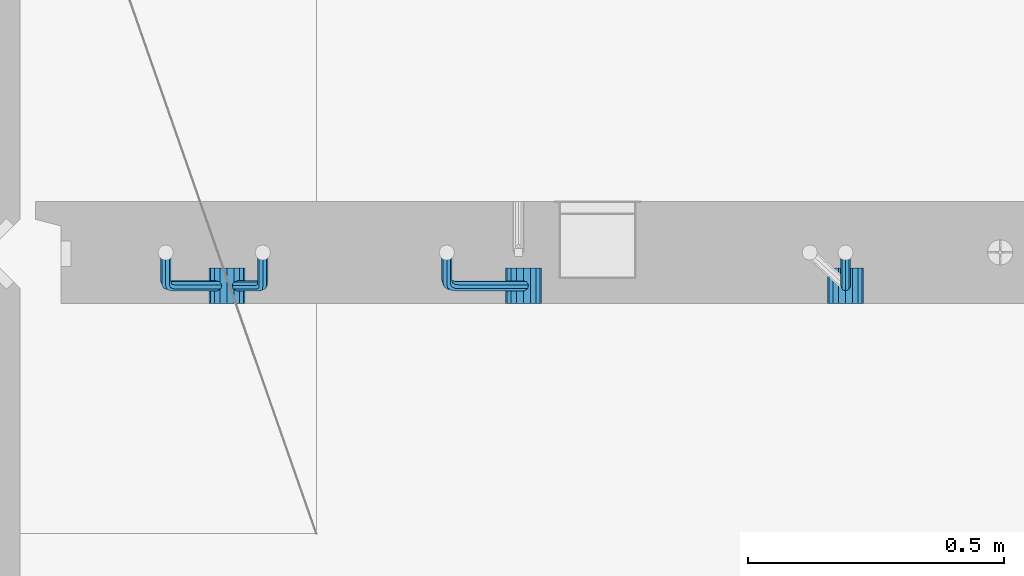
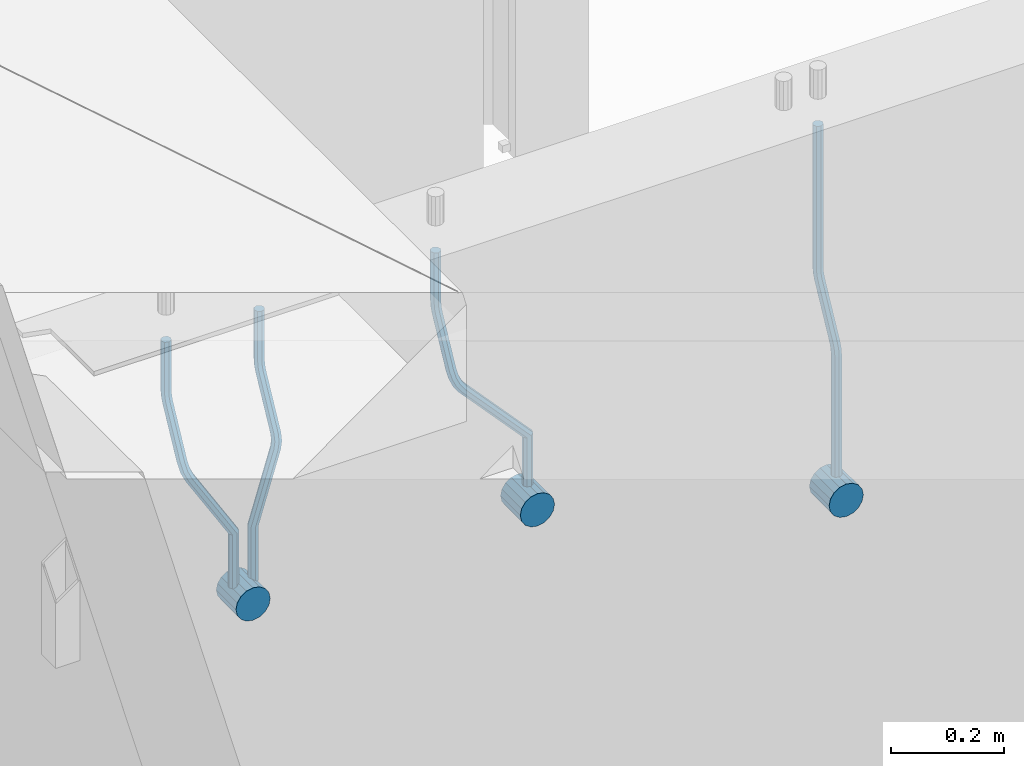
# One storey, part 154 of 352: 7 beams, 1 element without a shape of its own.
"""IFC2X3 building model written with IfcOpenShell, lengths in millimetres."""

from ifc_helpers import new_model, si_unit, frame, origin_with_axes, place, context, subcontext, project, spatial, faceted_brep, material, type_object, element, aggregate, save


model = new_model("IFC2X3")

# Units and contexts
model_context = context("Model", 3, precision=1e-05, world=origin_with_axes())
body_context = subcontext(model_context, "Body", "Model", "MODEL_VIEW")
ifc_project = project(units=[si_unit("LENGTHUNIT", "METRE", prefix="MILLI"), si_unit("AREAUNIT", "SQUARE_METRE"), si_unit("VOLUMEUNIT", "CUBIC_METRE"), si_unit("MASSUNIT", "GRAM", prefix="KILO"), si_unit("TIMEUNIT", "SECOND"), si_unit("PLANEANGLEUNIT", "RADIAN"), si_unit("SOLIDANGLEUNIT", "STERADIAN"), si_unit("THERMODYNAMICTEMPERATUREUNIT", "DEGREE_CELSIUS"), si_unit("LUMINOUSINTENSITYUNIT", "LUMEN")], contexts=[model_context])

# Site, building, storey
site_placement = place(None, origin_with_axes())
site = spatial("IfcSite", under=ifc_project, at=site_placement, CompositionType="ELEMENT")
building_placement = place(site_placement, origin_with_axes())
building = spatial("IfcBuilding", under=site, at=building_placement, CompositionType="ELEMENT")
storey_placement = place(building_placement, origin_with_axes())
storey = spatial("IfcBuildingStorey", under=building, at=storey_placement, Name="6", CompositionType="ELEMENT", Elevation=0.0)

# Assembly, beams
assembly_placement = place(storey_placement, origin_with_axes())
assembly = element("IfcElementAssembly", 1, at=assembly_placement, inside=storey, AssemblyPlace="NOTDEFINED", PredefinedType="REINFORCEMENT_UNIT")
ifc_material = material()
beam_type_1 = type_object("IfcBeamType", Name="D20", PredefinedType="NOTDEFINED")
beam_1_placement = place(assembly_placement, frame((9615.0034031366, 16979.9000008034, 99407.5), z_axis=(-0.000415599999849952, -0.999999913638316, 0.0), x_axis=(0.0, 0.0, -1.0)))
beam_1 = element("IfcBeam", 2, at=beam_1_placement, type_object=beam_type_1, material=ifc_material, Name="JM20", ObjectType="D20", context=body_context, shape_type="Brep", body=[
    faceted_brep([(0.0, -10.0, 0.0), (-4.19531716033816e-08, -7.07106781186667, -7.07106781187031), (308.817759199839, -7.07106784567077, -7.07106781098628), (308.817759199388, -10.0000000315576, 1.18961906991899e-09), (0.0, 0.0, -10.0), (308.817759200625, -3.38059180648997e-08, -9.99999999911961), (4.196772351861e-08, 7.07106781186303, -7.07106781186667), (308.817759201396, 7.07106777806075, -7.07106781098992), (0.0, 10.0, 0.0), (308.817759201687, 9.99999996619408, 8.76752892509103e-10), (4.196772351861e-08, 7.07106781185939, 7.07106781185939), (308.817759201353, 7.07106777805893, 7.07106781273978), (0.0, 0.0, 10.0), (308.817759200567, -3.38059180648997e-08, 10.0000000008768), (-4.19531716033816e-08, -7.07106781187031, 7.07106781185939), (308.817759199781, -7.07106784567259, 7.07106781274342), (323.108969574154, 0.000717635259206872, -8.27316123493802), (322.412036484602, -7.07038517474393, -5.42844102338131), (320.72809124495, -9.99940192615759, 1.43915193649809), (319.043566138222, -7.07055433041933, 8.30667482965873), (318.345233125816, 0.000478413006931078, 11.1512258851908), (319.042166215368, 7.07158122300643, 8.30650567364501), (320.726111455049, 10.0005979744237, 1.4389127137656), (322.410636561748, 7.07175037869092, -5.42861017940231), (335.221090258594, 7.07375888522984, -0.59577927861028), (336.577559329642, 0.00282932867594354, -3.19204402394098), (331.949003496353, 10.0023575726736, 5.67282516818887), (328.678043090971, 7.07309199865631, 11.9417058486688), (327.324293285914, 0.00188620863991673, 14.5386374811205), (328.680762356948, -7.06904334791398, 11.9423727357971), (331.952849119407, -9.99764203791528, 5.67376828873239), (335.223809524556, -7.06837646134409, -0.59511239150379), (438.031978881656, -7.04607830785426, 53.0582885393342), (434.761018476231, -9.97534387865016, 59.3271692200688), (439.385728686641, 0.0251274821457628, 50.4613569068679), (438.02925961549, 7.0960570387233, 53.0576216521513), (434.757172853177, 10.0246557262235, 59.326226098925), (431.486212447766, 7.0953901522571, 65.5951067794085), (430.132462642781, 0.0241843622607121, 68.1920384118748), (431.488931713931, -7.04674519431865, 65.5957736665914), (448.364788846782, 0.0265352911246737, 53.8487685030559), (447.667855771331, -7.04456751813632, 56.6934887198913), (445.983910537514, -9.97358426776555, 63.5610816819462), (444.29938542498, -7.04473667025195, 70.428604572935), (443.601052398531, 0.0262960739091795, 73.2731556232175), (444.297985473939, 7.09739888316835, 70.4284354063821), (445.981930707741, 10.0264156328012, 63.5608424443053), (447.666455820276, 7.09756803528398, 56.6933195533311), (457.892262743961, 7.0980815803614, 57.9289265681182), (457.892262772089, 0.0270137655697908, 54.999994387068), (457.892262732348, 10.0270137755506, 64.9999943770345), (457.892262744092, 7.09808159448221, 72.0710621918224), (457.89226277222, 0.0270137855477515, 74.9999943870425), (457.89226280032, -7.04405402924385, 72.0710622060069), (457.892262811918, -9.97298622770904, 64.9999943967923), (457.892262800189, -7.04405404336103, 57.9289265822954), (717.500000028129, -7.04405301280349, 57.928926581666), (717.500000039799, -9.97298519384276, 64.9999943964685), (717.499999999956, 0.0270147961218754, 54.999994386435), (717.499999971798, 7.09808261092803, 57.9289265674743), (717.499999960128, 10.0270148061572, 64.9999943763978), (717.499999971813, 7.09808262511979, 72.071062191204), (717.499999999985, 0.0270148161926045, 74.999994386435), (717.500000028143, -7.04405299861173, 72.0710622053957)], [[[0, 1, 2, 3]], [[1, 4, 5, 2]], [[4, 6, 7, 5]], [[6, 8, 9, 7]], [[8, 10, 11, 9]], [[10, 12, 13, 11]], [[12, 14, 15, 13]], [[14, 0, 3, 15]], [[14, 12, 10, 8, 6, 4, 1, 0]], [[2, 5, 16, 17]], [[3, 2, 17, 18]], [[15, 3, 18, 19]], [[13, 15, 19, 20]], [[11, 13, 20, 21]], [[9, 11, 21, 22]], [[7, 9, 22, 23]], [[5, 7, 23, 16]], [[23, 24, 25, 16]], [[22, 26, 24, 23]], [[21, 27, 26, 22]], [[20, 28, 27, 21]], [[19, 29, 28, 20]], [[18, 30, 29, 19]], [[17, 31, 30, 18]], [[16, 25, 31, 17]], [[30, 31, 32, 33]], [[31, 25, 34, 32]], [[25, 24, 35, 34]], [[24, 26, 36, 35]], [[26, 27, 37, 36]], [[27, 28, 38, 37]], [[28, 29, 39, 38]], [[29, 30, 33, 39]], [[32, 34, 40, 41]], [[33, 32, 41, 42]], [[39, 33, 42, 43]], [[38, 39, 43, 44]], [[37, 38, 44, 45]], [[36, 37, 45, 46]], [[35, 36, 46, 47]], [[34, 35, 47, 40]], [[47, 48, 49, 40]], [[46, 50, 48, 47]], [[45, 51, 50, 46]], [[44, 52, 51, 45]], [[43, 53, 52, 44]], [[42, 54, 53, 43]], [[41, 55, 54, 42]], [[40, 49, 55, 41]], [[54, 55, 56, 57]], [[55, 49, 58, 56]], [[49, 48, 59, 58]], [[48, 50, 60, 59]], [[50, 51, 61, 60]], [[51, 52, 62, 61]], [[52, 53, 63, 62]], [[53, 54, 57, 63]], [[58, 59, 60, 61, 62, 63, 57, 56]]]),
])
beam_2_placement = place(assembly_placement, frame((8835.00340324668, 16979.9000008034, 99407.5), z_axis=(-0.000415599999849952, -0.999999913638316, 0.0), x_axis=(0.0, 0.0, -1.0)))
beam_2 = element("IfcBeam", 3, at=beam_2_placement, type_object=beam_type_1, material=ifc_material, Name="JM20", ObjectType="D20", context=body_context, shape_type="Brep", body=[
    faceted_brep([(0.0, -10.0, 0.0), (-4.19531716033816e-08, -7.07106781186667, -7.07106781187031), (108.817745274035, -7.07106780534923, -7.07106781138282), (108.817745274282, -9.99999999387728, 6.25732354819775e-10), (0.0, 0.0, -10.0), (108.817745273627, 6.5174390329048e-09, -9.99999999951979), (4.196772351861e-08, 7.07106781186303, -7.07106781186667), (108.817745273191, 7.07106781838229, -7.07106781138646), (0.0, 10.0, 0.0), (108.817745272972, 10.0000000065156, 4.80213202536106e-10), (4.196772351861e-08, 7.07106781185939, 7.07106781185939), (108.817745273118, 7.07106781838047, 7.07106781234688), (0.0, 0.0, 10.0), (108.817745273511, 6.51562004350126e-09, 10.0000000004839), (-4.19531716033816e-08, -7.07106781187031, 7.07106781185939), (108.817745273947, -7.07106780535105, 7.07106781234688), (123.108954183059, 0.000717681035894202, -8.27316159443217), (122.412021172189, -7.07038512938016, -5.42844136475105), (120.72807610796, -9.99940188179062, 1.43915163770362), (119.043551170704, -7.07055428705462, 8.30667457294476), (118.345218222516, 0.000478455955089885, 11.1512256454189), (119.0421512334, 7.07158126637114, 8.30650541574869), (120.726096297614, 10.0005980187834, 1.43891241329038), (122.410621234856, 7.0717504240456, -5.42861052196531), (135.22107377628, 7.07375894905454, -0.595780608462519), (136.577542729705, 0.00282939387761871, -3.19204541917861), (131.948987323645, 10.0023576331841, 5.67282400158729), (128.678027238435, 7.07309205585807, 11.9417048475552), (127.324277576598, 0.00188626447015849, 14.5386365507547), (128.680746529979, -7.06904329070858, 11.9423717400241), (131.952832982774, -9.99764197422519, 5.67376712984333), (135.223793067897, -7.06837639751029, -0.595113715968182), (228.618473932263, -7.04811975626581, 48.1455814515648), (225.347513847039, -9.97738533437769, 54.4144622980784), (229.972223594217, 0.0230860351002775, 45.5486497482525), (228.615754640981, 7.0940155903063, 48.1449145588849), (225.343668188434, 10.0226142745032, 54.413519168902), (222.072708103209, 7.0933486972317, 60.6824000149136), (220.71895844127, 0.0221429058692593, 63.2793317182222), (222.075427394506, -7.04878664933858, 60.6830669075935), (242.359530626607, -5.11807977741773, 54.2178725378544), (240.589998539246, -7.8364579297413, 61.1502473240325), (237.467032239641, -4.88691414189452, 67.4847494116439), (234.820023031163, 2.00274883800921, 69.5107133886158), (234.199553008453, 8.79665987653607, 66.041357034137), (235.9690850958, 11.515038028856, 59.108982247948), (239.092051395462, 8.56549424101649, 52.7744801603476), (241.739060603926, 1.67583126110367, 50.7485161833647), (253.320593995435, 6.49475796966908, 54.0461912154642), (255.884193780192, 0.509358169847474, 58.0688258176233), (249.403367901468, 12.8559000820806, 55.7104792064529), (246.427173417251, 15.8665137298067, 62.0867724571763), (246.135424907392, 13.7630222690877, 69.4399248590198), (248.699024692221, 7.77762246929342, 73.462559461208), (252.616250786203, 1.41648035689104, 71.7982714702011), (255.592445270362, -1.59413329085874, 65.4219782194778), (263.775218458322, 14.0880763316163, 55.1735662778046), (268.092877162446, 9.37667043252804, 59.3853499298057), (258.711370403718, 19.6164132468075, 56.7142082202008), (255.867666511243, 22.72325639054, 63.1047886019151), (256.909909953785, 21.588659185405, 70.6017921067651), (261.227568657952, 16.8772532863513, 74.8135757587734), (266.291416712571, 11.348916371182, 73.2729338163554), (269.135120604697, 8.24207322799703, 66.8823534341354), (411.777331932535, 141.004054536572, 59.330645583992), (412.819575375106, 139.86945733149, 66.8276490888165), (407.459673228295, 145.71546043558, 55.1188619320019), (402.395825173633, 151.243797350722, 56.6595038743981), (399.552121281173, 154.350640494475, 63.0500842560868), (400.594364723744, 153.216043289394, 70.547087760915), (404.912023427984, 148.504637390388, 74.7588714129015), (409.975871482646, 142.976300475242, 73.2182294705053), (412.588360762704, 141.747027069805, 59.3303368045817), (413.18825896435, 140.207203377095, 66.8275087215443), (410.103187350978, 148.137147940774, 55.1178554785947), (407.188519608899, 155.634319848998, 56.6576791731022), (405.551730369989, 159.846801170075, 63.047800051525), (406.151628571635, 158.306977477367, 70.5449719684912), (408.636801983361, 151.916856606398, 74.7574532944818), (411.551469725426, 144.419684698174, 73.2176295999743), (413.688258959737, 141.747027073105, 59.3303368045781), (413.68825896435, 140.207203378595, 66.8275087215443), (413.688258940572, 148.137147951529, 55.1178554785911), (413.688258918075, 155.634319868494, 56.6576791730986), (413.688258905444, 159.846801194481, 63.0478000515213), (413.688258910042, 158.306977499973, 70.5449719684912), (413.688258929222, 151.916856621549, 74.7574532944782), (413.688258951704, 144.419684704584, 73.2176295999707), (517.499999574822, 141.74702738449, 59.3303368045817), (517.499999579435, 140.207203689981, 66.8275087215443), (517.499999555657, 148.137148262915, 55.1178554785947), (517.499999533175, 155.634320179879, 56.6576791731022), (517.499999520529, 159.846801505866, 63.047800051525), (517.499999525127, 158.306977811359, 70.5449719684912), (517.499999544307, 151.916856932934, 74.7574532944818), (517.499999566789, 144.41968501597, 73.2176295999743)], [[[0, 1, 2, 3]], [[1, 4, 5, 2]], [[4, 6, 7, 5]], [[6, 8, 9, 7]], [[8, 10, 11, 9]], [[10, 12, 13, 11]], [[12, 14, 15, 13]], [[14, 0, 3, 15]], [[14, 12, 10, 8, 6, 4, 1, 0]], [[2, 5, 16, 17]], [[3, 2, 17, 18]], [[15, 3, 18, 19]], [[13, 15, 19, 20]], [[11, 13, 20, 21]], [[9, 11, 21, 22]], [[7, 9, 22, 23]], [[5, 7, 23, 16]], [[23, 24, 25, 16]], [[22, 26, 24, 23]], [[21, 27, 26, 22]], [[20, 28, 27, 21]], [[19, 29, 28, 20]], [[18, 30, 29, 19]], [[17, 31, 30, 18]], [[16, 25, 31, 17]], [[30, 31, 32, 33]], [[31, 25, 34, 32]], [[25, 24, 35, 34]], [[24, 26, 36, 35]], [[26, 27, 37, 36]], [[27, 28, 38, 37]], [[28, 29, 39, 38]], [[29, 30, 33, 39]], [[33, 32, 40, 41]], [[39, 33, 41, 42]], [[38, 39, 42, 43]], [[37, 38, 43, 44]], [[36, 37, 44, 45]], [[35, 36, 45, 46]], [[34, 35, 46, 47]], [[32, 34, 47, 40]], [[47, 48, 49, 40]], [[46, 50, 48, 47]], [[45, 51, 50, 46]], [[44, 52, 51, 45]], [[43, 53, 52, 44]], [[42, 54, 53, 43]], [[41, 55, 54, 42]], [[40, 49, 55, 41]], [[48, 56, 57, 49]], [[50, 58, 56, 48]], [[51, 59, 58, 50]], [[52, 60, 59, 51]], [[53, 61, 60, 52]], [[54, 62, 61, 53]], [[55, 63, 62, 54]], [[49, 57, 63, 55]], [[63, 57, 64, 65]], [[57, 56, 66, 64]], [[56, 58, 67, 66]], [[58, 59, 68, 67]], [[59, 60, 69, 68]], [[60, 61, 70, 69]], [[61, 62, 71, 70]], [[62, 63, 65, 71]], [[65, 64, 72, 73]], [[64, 66, 74, 72]], [[66, 67, 75, 74]], [[67, 68, 76, 75]], [[68, 69, 77, 76]], [[69, 70, 78, 77]], [[70, 71, 79, 78]], [[71, 65, 73, 79]], [[73, 72, 80, 81]], [[72, 74, 82, 80]], [[74, 75, 83, 82]], [[75, 76, 84, 83]], [[76, 77, 85, 84]], [[77, 78, 86, 85]], [[78, 79, 87, 86]], [[79, 73, 81, 87]], [[81, 80, 88, 89]], [[80, 82, 90, 88]], [[82, 83, 91, 90]], [[83, 84, 92, 91]], [[84, 85, 93, 92]], [[85, 86, 94, 93]], [[86, 87, 95, 94]], [[87, 81, 89, 95]], [[90, 91, 92, 93, 94, 95, 89, 88]]]),
])
beam_3_placement = place(assembly_placement, frame((8475.00340324668, 16979.9000008034, 99407.5), z_axis=(-0.000415599999849952, -0.999999913638316, 0.0), x_axis=(0.0, 0.0, -1.0)))
beam_3 = element("IfcBeam", 4, at=beam_3_placement, type_object=beam_type_1, material=ifc_material, Name="JM20", ObjectType="D20", context=body_context, shape_type="Brep", body=[
    faceted_brep([(0.0, -10.0, 0.0), (-4.19531716033816e-08, -7.07106781186667, -7.07106781187031), (108.817745274035, -7.07106780534923, -7.07106781138282), (108.817745274282, -9.99999999387728, 6.25732354819775e-10), (0.0, 0.0, -10.0), (108.817745273627, 6.5174390329048e-09, -9.99999999951979), (4.196772351861e-08, 7.07106781186303, -7.07106781186667), (108.817745273191, 7.07106781838229, -7.07106781138646), (0.0, 10.0, 0.0), (108.817745272972, 10.0000000065156, 4.80213202536106e-10), (4.196772351861e-08, 7.07106781185939, 7.07106781185939), (108.817745273118, 7.07106781838047, 7.07106781234688), (0.0, 0.0, 10.0), (108.817745273511, 6.51562004350126e-09, 10.0000000004839), (-4.19531716033816e-08, -7.07106781187031, 7.07106781185939), (108.817745273947, -7.07106780535105, 7.07106781234688), (123.108954183059, 0.000717681035894202, -8.27316159443217), (122.412021172189, -7.07038512938016, -5.42844136475105), (120.72807610796, -9.99940188179062, 1.43915163770362), (119.043551170704, -7.07055428705462, 8.30667457294476), (118.345218222516, 0.000478455955089885, 11.1512256454189), (119.0421512334, 7.07158126637114, 8.30650541574869), (120.726096297614, 10.0005980187834, 1.43891241329038), (122.410621234856, 7.0717504240456, -5.42861052196531), (135.22107377628, 7.07375894905454, -0.595780608462519), (136.577542729705, 0.00282939387761871, -3.19204541917861), (131.948987323645, 10.0023576331841, 5.67282400158729), (128.678027238435, 7.07309205585807, 11.9417048475552), (127.324277576598, 0.00188626447015849, 14.5386365507547), (128.680746529979, -7.06904329070858, 11.9423717400241), (131.952832982774, -9.99764197422519, 5.67376712984333), (135.223793067897, -7.06837639751029, -0.595113715968182), (236.184987141853, -7.04647863304126, 52.0943835719445), (232.914027056744, -9.97574421112949, 58.3632644184945), (237.538736803792, 0.0247271583230031, 49.4974518686358), (236.182267850556, 7.09565671352902, 52.093716679261), (232.910181397994, 10.0242553977168, 58.3623212892744), (229.639221312784, 7.0949898204417, 64.631202135286), (228.28547165083, 0.0237840290774329, 67.2281338385947), (229.64194060408, -7.04714552612859, 64.6318690279659), (248.6361426574, 6.07228546495571, 56.8411920703111), (248.347225361111, -0.863437898962729, 53.6176983169717), (246.616285773896, -7.90364889308694, 56.0708434545886), (244.457284830249, -10.9242873990424, 62.7636083320067), (243.134936001807, -8.15590434705155, 69.7754620538217), (243.423853298023, -1.22018098313129, 72.9989558071647), (245.154792885252, 5.82003001100384, 70.5458106695442), (247.313793828915, 8.84066851695206, 63.8530457921224), (262.262810178814, 5.37582167724941, 65.733133839356), (261.561593060862, 3.07645584421334, 58.4667829613572), (261.257873569193, 2.08769693226714, 72.5710415482208), (259.135461468584, -4.86177950991259, 74.9749524903455), (257.138854100602, -11.4016986008392, 71.5366882385752), (256.437636982591, -13.7010644331713, 64.2703373600561), (257.442573592241, -10.4129396888893, 57.4324296517152), (259.564985692865, -3.46346324671867, 55.0285187095906), (405.56030258059, -55.6424869289785, 57.4512270528103), (404.555365971013, -58.9306116739535, 64.2891347616751), (407.682714681185, -48.6930104868225, 55.0473161106529), (409.679322049255, -42.153091395905, 58.4855803623905), (410.380539167294, -39.8537255628671, 65.7519312403674), (409.375602557717, -43.1418503078439, 72.5898389492322), (407.253190457122, -50.09132675, 74.993749891386), (405.256583089053, -56.6312458409175, 71.5554856396557), (408.394915116543, -56.5080702894629, 57.4515867892878), (407.881249744809, -59.9462106727442, 64.2895568446584), (409.479769216079, -49.2417629119063, 55.0475441721828), (410.500319225088, -42.4037928534744, 58.4856845539216), (410.858740789379, -39.9997502352981, 65.751991928224), (410.345075417616, -43.4378906185757, 72.5899619835945), (409.26022131808, -50.7041979961323, 74.9940046006996), (408.239671309086, -57.5421680545642, 71.5558642189608), (411.358740838899, -56.5080702805735, 57.4515867892915), (411.358740849202, -59.9462106623123, 64.2895568446584), (411.358740817101, -49.2417629062693, 55.0475441721828), (411.358740796582, -42.4037928508988, 58.4856845539216), (411.358740789379, -39.9997502337974, 65.751991928224), (411.358740799667, -43.4378906155343, 72.5899619835945), (411.358740821452, -50.7041979898386, 74.9940046006996), (411.35874084197, -57.5421680452091, 71.5558642189608), (527.500000169515, -56.5080699322043, 57.4515867892878), (527.500000179818, -59.9462103139449, 64.2895568446584), (527.500000147716, -49.2417625579019, 55.0475441721828), (527.500000127198, -42.4037925025295, 58.4856845539216), (527.500000119981, -39.9997498854282, 65.751991928224), (527.500000130283, -43.4378902671669, 72.5899619835945), (527.500000152068, -50.7041976414694, 74.9940046006996), (527.500000172586, -57.5421676968399, 71.5558642189608)], [[[0, 1, 2, 3]], [[1, 4, 5, 2]], [[4, 6, 7, 5]], [[6, 8, 9, 7]], [[8, 10, 11, 9]], [[10, 12, 13, 11]], [[12, 14, 15, 13]], [[14, 0, 3, 15]], [[14, 12, 10, 8, 6, 4, 1, 0]], [[2, 5, 16, 17]], [[3, 2, 17, 18]], [[15, 3, 18, 19]], [[13, 15, 19, 20]], [[11, 13, 20, 21]], [[9, 11, 21, 22]], [[7, 9, 22, 23]], [[5, 7, 23, 16]], [[23, 24, 25, 16]], [[22, 26, 24, 23]], [[21, 27, 26, 22]], [[20, 28, 27, 21]], [[19, 29, 28, 20]], [[18, 30, 29, 19]], [[17, 31, 30, 18]], [[16, 25, 31, 17]], [[30, 31, 32, 33]], [[31, 25, 34, 32]], [[25, 24, 35, 34]], [[24, 26, 36, 35]], [[26, 27, 37, 36]], [[27, 28, 38, 37]], [[28, 29, 39, 38]], [[29, 30, 33, 39]], [[34, 35, 40, 41]], [[32, 34, 41, 42]], [[33, 32, 42, 43]], [[39, 33, 43, 44]], [[38, 39, 44, 45]], [[37, 38, 45, 46]], [[36, 37, 46, 47]], [[35, 36, 47, 40]], [[47, 48, 49, 40]], [[46, 50, 48, 47]], [[45, 51, 50, 46]], [[44, 52, 51, 45]], [[43, 53, 52, 44]], [[42, 54, 53, 43]], [[41, 55, 54, 42]], [[40, 49, 55, 41]], [[53, 54, 56, 57]], [[54, 55, 58, 56]], [[55, 49, 59, 58]], [[49, 48, 60, 59]], [[48, 50, 61, 60]], [[50, 51, 62, 61]], [[51, 52, 63, 62]], [[52, 53, 57, 63]], [[57, 56, 64, 65]], [[56, 58, 66, 64]], [[58, 59, 67, 66]], [[59, 60, 68, 67]], [[60, 61, 69, 68]], [[61, 62, 70, 69]], [[62, 63, 71, 70]], [[63, 57, 65, 71]], [[65, 64, 72, 73]], [[64, 66, 74, 72]], [[66, 67, 75, 74]], [[67, 68, 76, 75]], [[68, 69, 77, 76]], [[69, 70, 78, 77]], [[70, 71, 79, 78]], [[71, 65, 73, 79]], [[73, 72, 80, 81]], [[72, 74, 82, 80]], [[74, 75, 83, 82]], [[75, 76, 84, 83]], [[76, 77, 85, 84]], [[77, 78, 86, 85]], [[78, 79, 87, 86]], [[79, 73, 81, 87]], [[82, 83, 84, 85, 86, 87, 81, 80]]]),
])
beam_4_placement = place(assembly_placement, frame((8285.00340324668, 16979.9000008034, 99407.5), z_axis=(-0.000415599999849952, -0.999999913638316, 0.0), x_axis=(0.0, 0.0, -1.0)))
beam_4 = element("IfcBeam", 5, at=beam_4_placement, type_object=beam_type_1, material=ifc_material, Name="JM20", ObjectType="D20", context=body_context, shape_type="Brep", body=[
    faceted_brep([(0.0, -10.0, 0.0), (-4.19531716033816e-08, -7.07106781186667, -7.07106781187031), (108.817745274035, -7.07106780534923, -7.07106781138282), (108.817745274282, -9.99999999387728, 6.25732354819775e-10), (0.0, 0.0, -10.0), (108.817745273627, 6.5174390329048e-09, -9.99999999951979), (4.196772351861e-08, 7.07106781186303, -7.07106781186667), (108.817745273191, 7.07106781838229, -7.07106781138646), (0.0, 10.0, 0.0), (108.817745272972, 10.0000000065156, 4.80213202536106e-10), (4.196772351861e-08, 7.07106781185939, 7.07106781185939), (108.817745273118, 7.07106781838047, 7.07106781234688), (0.0, 0.0, 10.0), (108.817745273511, 6.51562004350126e-09, 10.0000000004839), (-4.19531716033816e-08, -7.07106781187031, 7.07106781185939), (108.817745273947, -7.07106780535105, 7.07106781234688), (123.108954183059, 0.000717681035894202, -8.27316159443217), (122.412021172189, -7.07038512938016, -5.42844136475105), (120.72807610796, -9.99940188179062, 1.43915163770362), (119.043551170704, -7.07055428705462, 8.30667457294476), (118.345218222516, 0.000478455955089885, 11.1512256454189), (119.0421512334, 7.07158126637114, 8.30650541574869), (120.726096297614, 10.0005980187834, 1.43891241329038), (122.410621234856, 7.0717504240456, -5.42861052196531), (135.22107377628, 7.07375894905454, -0.595780608462519), (136.577542729705, 0.00282939387761871, -3.19204541917861), (131.948987323645, 10.0023576331841, 5.67282400158729), (128.678027238435, 7.07309205585807, 11.9417048475552), (127.324277576598, 0.00188626447015849, 14.5386365507547), (128.680746529979, -7.06904329070858, 11.9423717400241), (131.952832982774, -9.99764197422519, 5.67376712984333), (135.223793067897, -7.06837639751029, -0.595113715968182), (232.402437428042, -7.04729904112355, 50.1203514230874), (229.131477342933, -9.97656461926999, 56.3892322695465), (233.756187089995, 0.0239067502407124, 47.5234197197824), (232.399718136745, 7.09483630544673, 50.1196845304112), (229.127631684183, 10.0234349896364, 56.3882891404246), (225.856671598973, 7.09416941235941, 62.6571699864289), (224.502921937034, 0.0229636209951423, 65.2541016897412), (225.859390890269, -7.04796593420906, 62.6578368791124), (249.189096393879, -4.47246690703469, 56.6819566015656), (248.077205390815, -7.070562329116, 63.794778990592), (245.438615273073, -4.04479441522199, 70.3110060036124), (242.818976346156, 2.83238302726022, 72.4135202319376), (241.752837564854, 9.53241272338892, 68.8706973556764), (242.864728567991, 12.130508145472, 61.7578749666827), (245.503318685674, 9.10474023159077, 55.2416479536478), (248.122957612577, 2.22756278908673, 53.1391337253044), (262.227655998417, 8.55574368060479, 55.0905560343417), (265.66954071114, 2.92161058118472, 58.9620696407692), (258.367889273839, 14.876528294435, 57.021495303452), (256.351239537093, 18.1813345207174, 63.6237694123665), (257.359032853405, 16.5342516931214, 71.0298557306051), (260.800917566128, 10.9001185936977, 74.9013693370434), (264.660684290735, 4.57933397990018, 72.9704300679259), (266.677334027001, 1.27452775464917, 66.3681559586585), (410.721160764631, 91.5081613346811, 58.9252530669619), (411.728954081002, 89.861078507096, 66.3313393852004), (407.279276051908, 97.1422944340902, 55.053739460498), (403.419509327403, 103.46307904791, 56.9846787295719), (401.402859590729, 106.767885274196, 63.5869528384683), (402.410652907114, 105.12080244661, 70.9930391567141), (405.852537619838, 99.4866693472013, 74.8645527631779), (409.712304344357, 93.1658847333838, 72.9336134941077), (411.611923002652, 92.0521714889783, 58.9250269763252), (412.155668410225, 90.1216833219078, 66.3312310778347), (409.754886469877, 98.6542099015223, 55.0531111083837), (407.672385626982, 106.060413996784, 56.9835992770786), (406.584321224072, 109.932329861462, 63.5856376951961), (407.12806663166, 108.001841694397, 70.9918417967092), (408.985103164436, 101.399803281851, 74.8637576646506), (411.06760400733, 93.9935991865859, 72.9332694959521), (412.655668404448, 92.0521714921069, 58.9250269763288), (412.655668410225, 90.1216833234084, 66.3312310778347), (412.655668384643, 98.6542099102207, 55.0531111083837), (412.655668362422, 106.06041401173, 56.9835992770822), (412.65566835081, 109.932329879672, 63.5856376951961), (412.655668356587, 108.001841710977, 70.9918417967056), (412.655668376392, 101.399803292861, 74.8637576646506), (412.655668398613, 93.9935991913499, 72.9332694959521), (527.499999723892, 92.0521718365853, 58.9250269763252), (527.499999729669, 90.1216836678886, 66.3312310778347), (527.499999704101, 98.6542102546991, 55.0531111083837), (527.499999681881, 106.060414356209, 56.9835992770786), (527.499999670254, 109.93233022415, 63.5856376951924), (527.499999676045, 108.001842055455, 70.9918417967056), (527.499999695836, 101.399803637341, 74.863757664647), (527.499999718057, 93.9935995358301, 72.9332694959521)], [[[0, 1, 2, 3]], [[1, 4, 5, 2]], [[4, 6, 7, 5]], [[6, 8, 9, 7]], [[8, 10, 11, 9]], [[10, 12, 13, 11]], [[12, 14, 15, 13]], [[14, 0, 3, 15]], [[14, 12, 10, 8, 6, 4, 1, 0]], [[2, 5, 16, 17]], [[3, 2, 17, 18]], [[15, 3, 18, 19]], [[13, 15, 19, 20]], [[11, 13, 20, 21]], [[9, 11, 21, 22]], [[7, 9, 22, 23]], [[5, 7, 23, 16]], [[23, 24, 25, 16]], [[22, 26, 24, 23]], [[21, 27, 26, 22]], [[20, 28, 27, 21]], [[19, 29, 28, 20]], [[18, 30, 29, 19]], [[17, 31, 30, 18]], [[16, 25, 31, 17]], [[30, 31, 32, 33]], [[31, 25, 34, 32]], [[25, 24, 35, 34]], [[24, 26, 36, 35]], [[26, 27, 37, 36]], [[27, 28, 38, 37]], [[28, 29, 39, 38]], [[29, 30, 33, 39]], [[33, 32, 40, 41]], [[39, 33, 41, 42]], [[38, 39, 42, 43]], [[37, 38, 43, 44]], [[36, 37, 44, 45]], [[35, 36, 45, 46]], [[34, 35, 46, 47]], [[32, 34, 47, 40]], [[47, 48, 49, 40]], [[46, 50, 48, 47]], [[45, 51, 50, 46]], [[44, 52, 51, 45]], [[43, 53, 52, 44]], [[42, 54, 53, 43]], [[41, 55, 54, 42]], [[40, 49, 55, 41]], [[55, 49, 56, 57]], [[49, 48, 58, 56]], [[48, 50, 59, 58]], [[50, 51, 60, 59]], [[51, 52, 61, 60]], [[52, 53, 62, 61]], [[53, 54, 63, 62]], [[54, 55, 57, 63]], [[57, 56, 64, 65]], [[56, 58, 66, 64]], [[58, 59, 67, 66]], [[59, 60, 68, 67]], [[60, 61, 69, 68]], [[61, 62, 70, 69]], [[62, 63, 71, 70]], [[63, 57, 65, 71]], [[65, 64, 72, 73]], [[64, 66, 74, 72]], [[66, 67, 75, 74]], [[67, 68, 76, 75]], [[68, 69, 77, 76]], [[69, 70, 78, 77]], [[70, 71, 79, 78]], [[71, 65, 73, 79]], [[73, 72, 80, 81]], [[72, 74, 82, 80]], [[74, 75, 83, 82]], [[75, 76, 84, 83]], [[76, 77, 85, 84]], [[77, 78, 86, 85]], [[78, 79, 87, 86]], [[79, 73, 81, 87]], [[82, 83, 84, 85, 86, 87, 81, 80]]]),
])
beam_type_2 = type_object("IfcBeamType", Name="D70", PredefinedType="NOTDEFINED")
beam_5_placement = place(assembly_placement, frame((9615.00340323833, 16879.9000008034, 98654.9999989631), z_axis=(0.0, 0.0, 1.0), x_axis=(0.0, 1.0, 0.0)))
beam_5 = element("IfcBeam", 6, at=beam_5_placement, type_object=beam_type_2, material=ifc_material, ObjectType="D70", context=body_context, shape_type="Brep", body=[
    faceted_brep([(0.0, -35.0, 0.0), (0.0, -32.3357836378964, -13.3939201327739), (70.0, -32.3357836378964, -13.3939201327739), (70.0, -35.0, 0.0), (0.0, -24.7487373415279, -24.7487373415352), (70.0, -24.7487373415279, -24.7487373415352), (0.0, -13.3939201327776, -32.3357836379), (70.0, -13.3939201327776, -32.3357836379), (0.0, 0.0, -35.0), (70.0, 0.0, -35.0), (0.0, 13.3939201327776, -32.3357836379), (70.0, 13.3939201327776, -32.3357836379), (0.0, 24.7487373415279, -24.7487373415352), (70.0, 24.7487373415279, -24.7487373415352), (0.0, 32.3357836378964, -13.3939201327739), (70.0, 32.3357836378964, -13.3939201327739), (0.0, 35.0, 0.0), (70.0, 35.0, 0.0), (0.0, 32.3357836378964, 13.3939201327739), (70.0, 32.3357836378964, 13.3939201327739), (0.0, 24.7487373415279, 24.7487373415352), (70.0, 24.7487373415279, 24.7487373415352), (0.0, 13.3939201327776, 32.3357836379), (70.0, 13.3939201327776, 32.3357836379), (0.0, 0.0, 35.0), (70.0, 0.0, 35.0), (0.0, -13.3939201327776, 32.3357836379), (70.0, -13.3939201327776, 32.3357836379), (0.0, -24.7487373415279, 24.7487373415352), (70.0, -24.7487373415279, 24.7487373415352), (0.0, -32.3357836378964, 13.3939201327739), (70.0, -32.3357836378964, 13.3939201327739)], [[[0, 1, 2, 3]], [[1, 4, 5, 2]], [[4, 6, 7, 5]], [[6, 8, 9, 7]], [[8, 10, 11, 9]], [[10, 12, 13, 11]], [[12, 14, 15, 13]], [[14, 16, 17, 15]], [[16, 18, 19, 17]], [[18, 20, 21, 19]], [[20, 22, 23, 21]], [[22, 24, 25, 23]], [[24, 26, 27, 25]], [[26, 28, 29, 27]], [[28, 30, 31, 29]], [[30, 0, 3, 31]], [[5, 7, 9, 11, 13, 15, 17, 19, 21, 23, 25, 27, 29, 31, 3, 2]], [[30, 28, 26, 24, 22, 20, 18, 16, 14, 12, 10, 8, 6, 4, 1, 0]]]),
])
beam_6_placement = place(assembly_placement, frame((8985.00340323833, 16879.9000008034, 98854.9999989631), z_axis=(0.0, 0.0, 1.0), x_axis=(0.0, 1.0, 0.0)))
beam_6 = element("IfcBeam", 7, at=beam_6_placement, type_object=beam_type_2, material=ifc_material, ObjectType="D70", context=body_context, shape_type="Brep", body=[
    faceted_brep([(0.0, -35.0, 0.0), (0.0, -32.3357836378964, -13.3939201327739), (70.0, -32.3357836378964, -13.3939201327739), (70.0, -35.0, 0.0), (0.0, -24.7487373415279, -24.7487373415352), (70.0, -24.7487373415279, -24.7487373415352), (0.0, -13.3939201327776, -32.3357836379), (70.0, -13.3939201327776, -32.3357836379), (0.0, 0.0, -35.0), (70.0, 0.0, -35.0), (0.0, 13.3939201327776, -32.3357836379), (70.0, 13.3939201327776, -32.3357836379), (0.0, 24.7487373415279, -24.7487373415352), (70.0, 24.7487373415279, -24.7487373415352), (0.0, 32.3357836378964, -13.3939201327739), (70.0, 32.3357836378964, -13.3939201327739), (0.0, 35.0, 0.0), (70.0, 35.0, 0.0), (0.0, 32.3357836378964, 13.3939201327739), (70.0, 32.3357836378964, 13.3939201327739), (0.0, 24.7487373415279, 24.7487373415352), (70.0, 24.7487373415279, 24.7487373415352), (0.0, 13.3939201327776, 32.3357836379), (70.0, 13.3939201327776, 32.3357836379), (0.0, 0.0, 35.0), (70.0, 0.0, 35.0), (0.0, -13.3939201327776, 32.3357836379), (70.0, -13.3939201327776, 32.3357836379), (0.0, -24.7487373415279, 24.7487373415352), (70.0, -24.7487373415279, 24.7487373415352), (0.0, -32.3357836378964, 13.3939201327739), (70.0, -32.3357836378964, 13.3939201327739)], [[[0, 1, 2, 3]], [[1, 4, 5, 2]], [[4, 6, 7, 5]], [[6, 8, 9, 7]], [[8, 10, 11, 9]], [[10, 12, 13, 11]], [[12, 14, 15, 13]], [[14, 16, 17, 15]], [[16, 18, 19, 17]], [[18, 20, 21, 19]], [[20, 22, 23, 21]], [[22, 24, 25, 23]], [[24, 26, 27, 25]], [[26, 28, 29, 27]], [[28, 30, 31, 29]], [[30, 0, 3, 31]], [[5, 7, 9, 11, 13, 15, 17, 19, 21, 23, 25, 27, 29, 31, 3, 2]], [[30, 28, 26, 24, 22, 20, 18, 16, 14, 12, 10, 8, 6, 4, 1, 0]]]),
])
beam_7_placement = place(assembly_placement, frame((8405.00340323833, 16879.9000008034, 98854.9999989631), z_axis=(0.0, 0.0, 1.0), x_axis=(0.0, 1.0, 0.0)))
beam_7 = element("IfcBeam", 8, at=beam_7_placement, type_object=beam_type_2, material=ifc_material, ObjectType="D70", context=body_context, shape_type="Brep", body=[
    faceted_brep([(0.0, -35.0, 0.0), (0.0, -32.3357836378964, -13.3939201327739), (70.0, -32.3357836378964, -13.3939201327739), (70.0, -35.0, 0.0), (0.0, -24.7487373415279, -24.7487373415352), (70.0, -24.7487373415279, -24.7487373415352), (0.0, -13.3939201327776, -32.3357836379), (70.0, -13.3939201327776, -32.3357836379), (0.0, 0.0, -35.0), (70.0, 0.0, -35.0), (0.0, 13.3939201327776, -32.3357836379), (70.0, 13.3939201327776, -32.3357836379), (0.0, 24.7487373415279, -24.7487373415352), (70.0, 24.7487373415279, -24.7487373415352), (0.0, 32.3357836378964, -13.3939201327739), (70.0, 32.3357836378964, -13.3939201327739), (0.0, 35.0, 0.0), (70.0, 35.0, 0.0), (0.0, 32.3357836378964, 13.3939201327739), (70.0, 32.3357836378964, 13.3939201327739), (0.0, 24.7487373415279, 24.7487373415352), (70.0, 24.7487373415279, 24.7487373415352), (0.0, 13.3939201327776, 32.3357836379), (70.0, 13.3939201327776, 32.3357836379), (0.0, 0.0, 35.0), (70.0, 0.0, 35.0), (0.0, -13.3939201327776, 32.3357836379), (70.0, -13.3939201327776, 32.3357836379), (0.0, -24.7487373415279, 24.7487373415352), (70.0, -24.7487373415279, 24.7487373415352), (0.0, -32.3357836378964, 13.3939201327739), (70.0, -32.3357836378964, 13.3939201327739)], [[[0, 1, 2, 3]], [[1, 4, 5, 2]], [[4, 6, 7, 5]], [[6, 8, 9, 7]], [[8, 10, 11, 9]], [[10, 12, 13, 11]], [[12, 14, 15, 13]], [[14, 16, 17, 15]], [[16, 18, 19, 17]], [[18, 20, 21, 19]], [[20, 22, 23, 21]], [[22, 24, 25, 23]], [[24, 26, 27, 25]], [[26, 28, 29, 27]], [[28, 30, 31, 29]], [[30, 0, 3, 31]], [[5, 7, 9, 11, 13, 15, 17, 19, 21, 23, 25, 27, 29, 31, 3, 2]], [[30, 28, 26, 24, 22, 20, 18, 16, 14, 12, 10, 8, 6, 4, 1, 0]]]),
])
aggregate(assembly, [beam_5, beam_1, beam_6, beam_2, beam_3, beam_7, beam_4])

save(model, "model.ifc")
